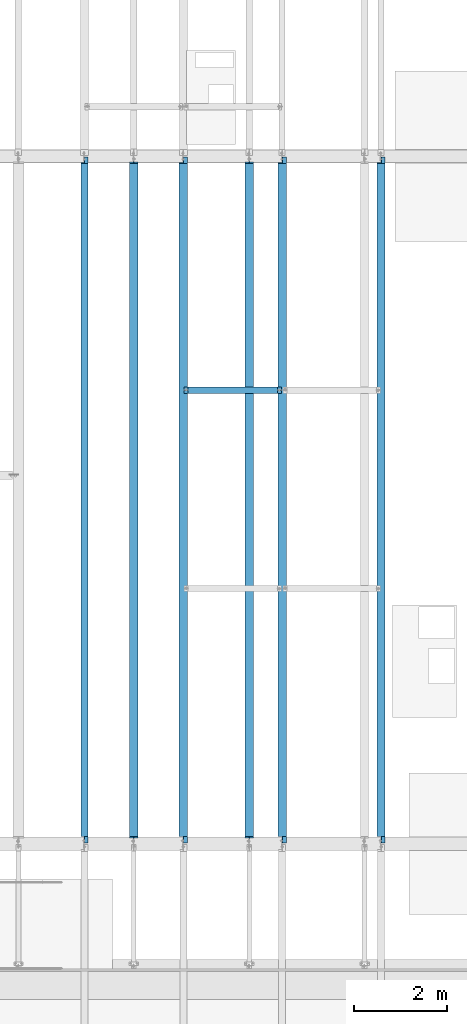
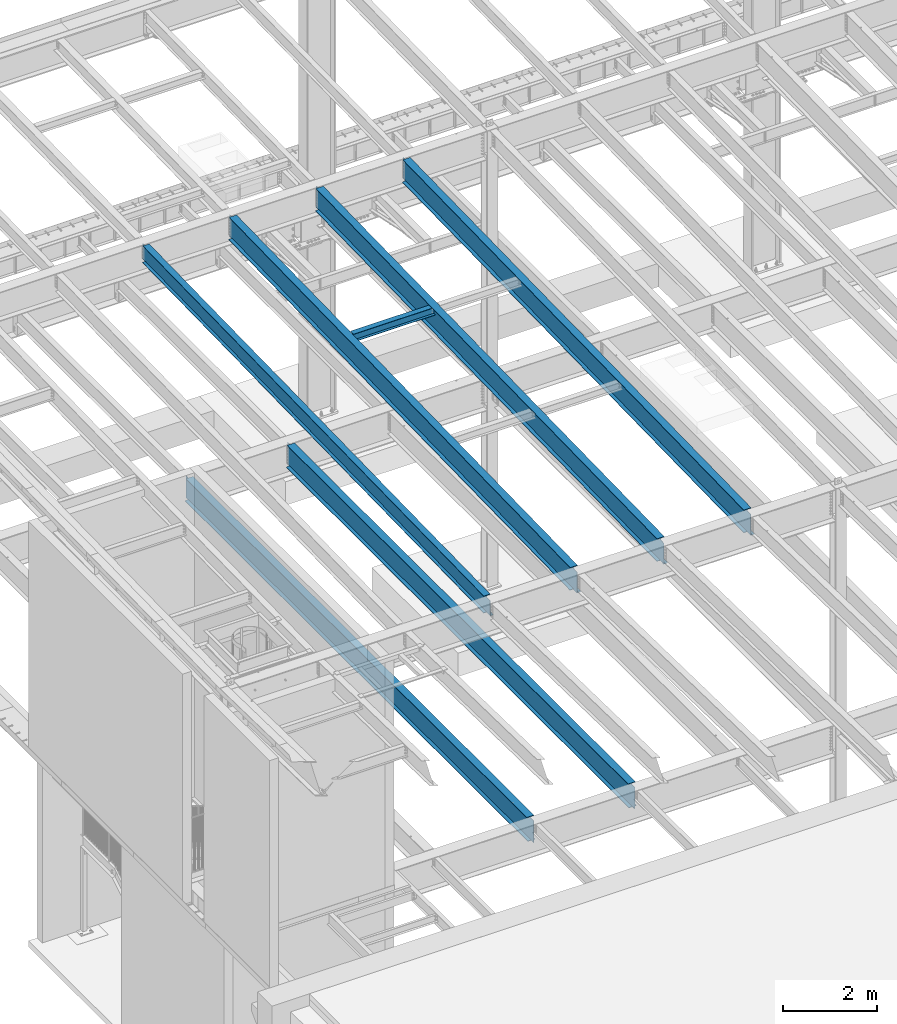
# One storey, part 1097 of 1763: 7 beams, 7 elements without a shape of their own.
"""IFC2X3 building model written with IfcOpenShell, lengths in millimetres."""

from ifc_helpers import new_model, si_unit, frame, origin_with_axes, place, context, subcontext, project, spatial, faceted_brep, material, type_object, element, aggregate, save


model = new_model("IFC2X3")

# Units and contexts
model_context = context("Model", 3, precision=1e-05, world=origin_with_axes())
body_context = subcontext(model_context, "Body", "Model", "MODEL_VIEW")
ifc_project = project(units=[si_unit("LENGTHUNIT", "METRE", prefix="MILLI"), si_unit("AREAUNIT", "SQUARE_METRE"), si_unit("VOLUMEUNIT", "CUBIC_METRE"), si_unit("MASSUNIT", "GRAM", prefix="KILO"), si_unit("TIMEUNIT", "SECOND"), si_unit("PLANEANGLEUNIT", "RADIAN"), si_unit("SOLIDANGLEUNIT", "STERADIAN"), si_unit("THERMODYNAMICTEMPERATUREUNIT", "DEGREE_CELSIUS"), si_unit("LUMINOUSINTENSITYUNIT", "LUMEN")], contexts=[model_context])

# Site, building, storey
site_placement = place(None, origin_with_axes())
site = spatial("IfcSite", under=ifc_project, at=site_placement, CompositionType="ELEMENT")
building_placement = place(site_placement, origin_with_axes())
building = spatial("IfcBuilding", under=site, at=building_placement, Name="Undefined", CompositionType="ELEMENT")
storey_placement = place(building_placement, origin_with_axes())
storey = spatial("IfcBuildingStorey", under=building, at=storey_placement, Name="Undefined", CompositionType="ELEMENT", Elevation=0.0)

# Assembly, beam
assembly_1_placement = place(storey_placement, origin_with_axes())
assembly_1 = element("IfcElementAssembly", 1, at=assembly_1_placement, inside=storey, Name="BEAM", AssemblyPlace="NOTDEFINED", PredefinedType="RIGID_FRAME")
ifc_material = material(Name="STEEL/A992")
beam_type_1 = type_object("IfcBeamType", Name="W8X18", PredefinedType="NOTDEFINED")
beam_1_placement = place(assembly_1_placement, frame((-78870.0658451269, 39776.4, 11388.9111170495), z_axis=(0.0, 0.0, 1.0), x_axis=(1.0, 0.0, 0.0)))
beam_1 = element("IfcBeam", 2, at=beam_1_placement, type_object=beam_type_1, material=ifc_material, Name="BEAM", ObjectType="W8X18", context=body_context, shape_type="Brep", body=[
    faceted_brep([(2030.05010096592, -3.17500000000018, 68.5472454972532), (2030.05010096592, 3.17500000000018, 68.5472454972532), (2029.18911617418, 3.17500000000291, 69.8358002989789), (2029.18911617418, -3.17500000000291, 69.8358002989789), (2034.17027743408, -3.17500000000018, 65.7942315967757), (2034.17027743408, 3.17500000000018, 65.7942315967757), (2039.03035695212, -3.17500000000018, 64.8275016741882), (2039.03035695212, 3.17500000000018, 64.8275016741882), (2108.88035714286, -3.17500000000018, 64.8275016741882), (2108.88035714286, 3.17500000000018, 64.8275016741882), (2028.46260401768, -3.17500000000291, 70.3212402021363), (2028.46260401768, 3.17500000000291, 70.3212402021363), (2025.7095901172, 3.17500000000291, 74.44141667029), (2025.7095901172, -3.17500000000291, 74.44141667029), (2024.74286019462, 3.17500000000291, 79.3014961883364), (2024.74286019462, -3.17500000000291, 79.3014961883364), (2024.74286019463, 66.6750000000002, 95.25), (2024.74286019463, 3.17500000000018, 95.25), (101.599996948244, 3.17500000000018, 95.25), (101.599996948244, 66.6750000000002, 95.25), (2024.74286019463, -66.6750000000002, 95.25), (2024.74286019463, -66.6750000000002, 103.1875), (101.599996948244, -66.6750000000002, 103.1875), (101.599996948244, -66.6750000000002, 95.25), (2024.74286019463, 66.6750000000002, 103.1875), (101.599996948244, 66.6750000000002, 103.1875), (2024.74286019463, -3.17500000000018, 95.25), (101.599996948244, -3.17500000000018, 95.25), (101.599996948236, 3.17499999999927, 79.301496189446), (101.599996948236, -3.17499999999927, 79.301496189446), (100.633267025652, 3.17499999999927, 74.4414166713996), (100.633267025652, -3.17499999999927, 74.4414166713996), (97.8802531251713, 3.17499999999927, 70.3212402032459), (97.8802531251713, -3.17499999999927, 70.3212402032459), (97.153740969894, 3.17499999999927, 69.8358003008998), (97.153740969894, -3.17499999999927, 69.8358003008998), (96.2927561769247, 3.17500000000018, 68.5472454911378), (96.2927561769247, -3.17500000000018, 68.5472454911378), (92.1725797087711, 3.17500000000018, 65.7942315906603), (92.1725797087711, -3.17500000000018, 65.7942315906603), (87.3125001907247, 3.17500000000018, 64.8275016680727), (87.3125001907247, -3.17500000000018, 64.8275016680727), (17.4624999999905, 3.17500000000018, 64.8275016680727), (17.4624999999905, -3.17500000000018, 64.8275016680727), (17.4624999999905, 3.17500000000018, -95.25), (17.4624999999905, 66.6750000000002, -95.25), (17.4624999999905, 66.6750000000002, -103.1875), (17.4624999999905, -66.6750000000002, -103.1875), (17.4624999999905, -66.6750000000002, -95.25), (17.4624999999905, -3.17500000000018, -95.25), (2108.88035714286, 3.17500000000018, -95.25), (2108.88035714286, 66.6750000000002, -95.25), (2108.88035714286, 66.6750000000002, -103.1875), (2108.88035714286, -66.6750000000002, -103.1875), (2108.88035714286, -66.6750000000002, -95.25), (2108.88035714286, -3.17500000000018, -95.25)], [[[0, 1, 2, 3]], [[4, 5, 1, 0]], [[6, 7, 5, 4]], [[8, 9, 7, 6]], [[10, 11, 12, 13]], [[13, 12, 14, 15]], [[16, 17, 18, 19]], [[20, 21, 22, 23]], [[21, 24, 25, 22]], [[24, 16, 19, 25]], [[21, 20, 26, 15, 14, 17, 16, 24]], [[26, 20, 23, 27]], [[22, 25, 19, 18, 28, 29, 27, 23]], [[29, 28, 30, 31]], [[31, 30, 32, 33]], [[33, 32, 34, 35]], [[35, 34, 36, 37]], [[37, 36, 38, 39]], [[39, 38, 40, 41]], [[41, 40, 42, 43]], [[44, 45, 46, 47, 48, 49, 43, 42]], [[45, 44, 50, 51]], [[46, 45, 51, 52]], [[47, 46, 52, 53]], [[48, 47, 53, 54]], [[49, 48, 54, 55]], [[4, 0, 3, 10, 13, 15, 26, 27, 29, 31, 33, 35, 37, 39, 41, 43, 49, 55, 8, 6]], [[11, 10, 3, 2]], [[50, 44, 42, 40, 38, 36, 34, 32, 30, 28, 18, 17, 14, 12, 11, 2, 1, 5, 7, 9]], [[55, 54, 53, 52, 51, 50, 9, 8]]]),
])
aggregate(assembly_1, [beam_1])

assembly_2_placement = place(storey_placement, origin_with_axes())
assembly_2 = element("IfcElementAssembly", 3, at=assembly_2_placement, inside=storey, Name="BEAM", AssemblyPlace="NOTDEFINED", PredefinedType="RIGID_FRAME")
beam_type_2 = type_object("IfcBeamType", Name="W18X35", PredefinedType="NOTDEFINED")
beam_2_placement = place(assembly_2_placement, frame((-80996.4087022698, 30027.4629676506, 11064.9232324289), z_axis=(0.0, -0.0206852279954837, 0.999786037781472), x_axis=(0.0, 0.999786037781472, 0.0206852279954825)))
beam_2 = element("IfcBeam", 4, at=beam_2_placement, type_object=beam_type_2, material=ifc_material, Name="BEAM", ObjectType="W18X35", context=body_context, shape_type="Brep", body=[
    faceted_brep([(161.234036217043, 4.26867060289806, -214.312499999869), (161.234036217025, 4.26882632687921, -225.424999999863), (10.5200655540102, 4.26881607816904, -225.424999999832), (10.7499793429743, 4.26866036980209, -214.312499999842), (161.234031325755, 76.1999999999971, -214.312499999867), (161.234031325748, 76.1999999999971, -225.424999999861), (161.234031013333, -3.96875, 180.714997672841), (161.234031013333, 3.96875, 180.714997672841), (160.267301090749, 3.96875, 175.854918154808), (160.267301090749, -3.96875, 175.854918154808), (157.514287190275, 3.96875, 171.734741686663), (157.514287190275, -3.96875, 171.734741686663), (153.394110722133, 3.96875, 168.981727786193), (153.394110722133, -3.96875, 168.981727786193), (148.534031204097, 3.96875, 168.014997863607), (148.534031204097, -3.96875, 168.014997863607), (18.6602033211384, 3.96875, 168.014997863631), (18.6602033211384, -3.96875, 168.014997863631), (10.7499793429743, -3.96875, -214.312499999842), (14757.8115434472, -3.96875, -214.312500002648), (14765.8531467846, -3.96875, 174.36500163611), (14641.5955948759, -3.96875, 174.365001636133), (14636.7355153579, -3.96875, 175.331731558719), (14632.6153388897, -3.96875, 178.084745459191), (14629.8623249892, -3.96875, 182.204921927336), (14628.8955950666, -3.96875, 187.065001445368), (14628.8955950666, -3.96875, 214.312499997053), (161.234030986467, -3.96875, 214.312499999809), (10.7499793429743, -76.1999999999971, -214.312499999842), (14757.8115434472, -76.1999999999971, -214.312500002648), (10.5200655540102, -76.1999999999971, -225.424999999832), (14757.5816296582, -76.1999999999971, -225.425000002639), (14641.5955921487, 4.26882640406257, -214.312500002627), (14641.5955921487, 4.26867068048159, -225.425000002617), (14641.5955830855, 76.1999999999971, -225.425000002617), (14641.5955830855, 76.1999999999971, -214.312500002628), (14757.8115434472, 4.26884104704368, -214.312500002648), (14757.5816296582, 4.26868529446074, -225.425000002639), (14757.8115434472, 3.96875, -214.312500002648), (14765.8531467846, 3.96875, 174.36500163611), (14641.5955948759, 3.96875, 174.365001636133), (14636.7355153579, 3.96875, 175.331731558719), (14632.6153388897, 3.96875, 178.084745459191), (14629.8623249892, 3.96875, 182.204921927336), (14628.8955950666, 3.96875, 187.065001445368), (14628.8955950666, -76.1999999999971, 225.424999997045), (14628.8955950666, -76.1999999999971, 214.312499997053), (14628.8955950666, 3.96875, 214.312499997053), (14628.8955950666, 76.1999999999971, 214.312499997053), (14628.8955950666, 76.1999999999971, 225.424999997045), (161.234030986467, 3.96875, 214.312499999809), (161.234030986467, 76.1999999999971, 214.312499999809), (161.23403098647, 76.1999999999971, 225.424999999799), (161.23403098647, -76.1999999999971, 225.424999999799), (161.234030986467, -76.1999999999971, 214.312499999809), (10.7499793429743, 3.96875, -214.312499999842)], [[[0, 1, 2, 3]], [[4, 5, 1, 0]], [[6, 7, 8, 9]], [[9, 8, 10, 11]], [[11, 10, 12, 13]], [[13, 12, 14, 15]], [[15, 14, 16, 17]], [[9, 11, 13, 15, 17, 18, 19, 20, 21, 22, 23, 24, 25, 26, 27, 6]], [[18, 28, 29, 19]], [[28, 30, 31, 29]], [[32, 33, 34, 35]], [[36, 37, 33, 32]], [[38, 39, 20, 19, 29, 31, 37, 36]], [[20, 39, 40, 21]], [[21, 40, 41, 22]], [[22, 41, 42, 23]], [[23, 42, 43, 24]], [[24, 43, 44, 25]], [[45, 46, 26, 25, 44, 47, 48, 49]], [[48, 47, 50, 51]], [[49, 48, 51, 52]], [[45, 49, 52, 53]], [[46, 45, 53, 54]], [[26, 46, 54, 27]], [[53, 52, 51, 50, 7, 6, 27, 54]], [[47, 44, 43, 42, 41, 40, 39, 38, 55, 16, 14, 12, 10, 8, 7, 50]], [[30, 28, 18, 17, 16, 55, 3, 2]], [[34, 33, 37, 31, 30, 2, 1, 5]], [[35, 34, 5, 4]], [[55, 38, 36, 32, 35, 4, 0, 3]]]),
])
aggregate(assembly_2, [beam_2])

assembly_3_placement = place(storey_placement, origin_with_axes())
assembly_3 = element("IfcElementAssembly", 5, at=assembly_3_placement, inside=storey, Name="BEAM", AssemblyPlace="NOTDEFINED", PredefinedType="RIGID_FRAME")
beam_type_3 = type_object("IfcBeamType", Name="W24X55", PredefinedType="NOTDEFINED")
beam_3_placement = place(assembly_3_placement, frame((-74617.3801308412, 30029.0063442244, 10990.3266966851), z_axis=(0.0, -0.0206852279954837, 0.999786037781472), x_axis=(0.0, 0.999786037781472, 0.0206852279954825)))
beam_3 = element("IfcBeam", 6, at=beam_3_placement, type_object=beam_type_3, material=ifc_material, Name="BEAM", ObjectType="W24X55", context=body_context, shape_type="Brep", body=[
    faceted_brep([(159.690329536948, 5.06237880352273, -287.337499999812), (159.690329536945, 5.06261812614684, -300.037499999804), (7.43265181667448, 5.06260883843788, -300.037499999775), (7.69541043263234, 5.06236953187909, -287.337499999783), (159.690324423107, 88.9000000000015, -287.337499999812), (159.690324423103, 88.9000000000015, -300.037499999802), (159.690324144543, -4.76249999999709, 255.327497672615), (159.690324144543, 4.76249999999709, 255.327497672615), (158.723594221956, 4.76249999999709, 250.467418154582), (158.723594221956, -4.76249999999709, 250.467418154582), (155.970580321482, 4.76249999999709, 246.347241686437), (155.970580321482, -4.76249999999709, 246.347241686437), (151.850403853339, 4.76249999999709, 243.594227785965), (151.850403853339, -4.76249999999709, 243.594227785965), (146.990324335304, 4.76249999999709, 242.627497863381), (146.990324335304, -4.76249999999709, 242.627497863381), (18.6602033210984, 4.76249999999709, 242.627497863405), (18.6602033210984, -4.76249999999709, 242.627497863405), (7.69541043263234, -4.76249999999709, -287.337499999783), (14754.7569745369, -4.76249999999709, -287.337500002592), (14765.8531467848, -4.76249999999709, 248.977501635871), (14640.0518880073, -4.76249999999709, 248.977501635894), (14635.1918084892, -4.76249999999709, 249.944231558482), (14631.0716320211, -4.76249999999709, 252.697245458956), (14628.3186181206, -4.76249999999709, 256.817421927099), (14627.351888198, -4.76249999999709, 261.677501445134), (14627.351888198, -4.76249999999709, 287.337499997), (159.690324117902, -4.76249999999709, 287.337499999756), (7.69541043263234, -88.9000000000015, -287.337499999783), (14754.7569745369, -88.9000000000015, -287.337500002592), (7.43265181667448, -88.9000000000015, -300.037499999775), (14754.4942159209, -88.9000000000015, -300.037500002583), (14640.051883239, 5.06261810508295, -287.33750000257), (14640.051883239, 5.06237878320098, -300.03750000256), (14640.0518719211, 88.9000000000015, -300.037500002562), (14640.0518719211, 88.9000000000015, -287.337500002572), (14754.7569745369, 5.0626335900306, -287.337500002592), (14754.4942159209, 5.06239423266379, -300.037500002583), (14754.7569745369, 4.76249999999709, -287.337500002592), (14765.8531467848, 4.76249999999709, 248.977501635871), (14640.0518880073, 4.76249999999709, 248.977501635894), (14635.1918084892, 4.76249999999709, 249.944231558482), (14631.0716320211, 4.76249999999709, 252.697245458956), (14628.3186181206, 4.76249999999709, 256.817421927099), (14627.351888198, 4.76249999999709, 261.677501445134), (14627.351888198, -88.9000000000015, 300.03749999699), (14627.351888198, -88.9000000000015, 287.337499997), (14627.351888198, 4.76249999999709, 287.337499997), (14627.351888198, 88.9000000000015, 287.337499997), (14627.351888198, 88.9000000000015, 300.03749999699), (159.690324117902, 4.76249999999709, 287.337499999756), (159.690324117902, 88.9000000000015, 287.337499999756), (159.690324117906, 88.9000000000015, 300.037499999746), (159.690324117906, -88.9000000000015, 300.037499999746), (159.690324117902, -88.9000000000015, 287.337499999756), (7.69541043263234, 4.76249999999709, -287.337499999783)], [[[0, 1, 2, 3]], [[4, 5, 1, 0]], [[6, 7, 8, 9]], [[9, 8, 10, 11]], [[11, 10, 12, 13]], [[13, 12, 14, 15]], [[15, 14, 16, 17]], [[9, 11, 13, 15, 17, 18, 19, 20, 21, 22, 23, 24, 25, 26, 27, 6]], [[18, 28, 29, 19]], [[28, 30, 31, 29]], [[32, 33, 34, 35]], [[36, 37, 33, 32]], [[38, 39, 20, 19, 29, 31, 37, 36]], [[20, 39, 40, 21]], [[21, 40, 41, 22]], [[22, 41, 42, 23]], [[23, 42, 43, 24]], [[24, 43, 44, 25]], [[45, 46, 26, 25, 44, 47, 48, 49]], [[48, 47, 50, 51]], [[49, 48, 51, 52]], [[45, 49, 52, 53]], [[46, 45, 53, 54]], [[26, 46, 54, 27]], [[53, 52, 51, 50, 7, 6, 27, 54]], [[47, 44, 43, 42, 41, 40, 39, 38, 55, 16, 14, 12, 10, 8, 7, 50]], [[30, 28, 18, 17, 16, 55, 3, 2]], [[34, 33, 37, 31, 30, 2, 1, 5]], [[35, 34, 5, 4]], [[55, 38, 36, 32, 35, 4, 0, 3]]]),
])
aggregate(assembly_3, [beam_3])

assembly_4_placement = place(storey_placement, origin_with_axes())
assembly_4 = element("IfcElementAssembly", 7, at=assembly_4_placement, inside=storey, Name="BEAM", AssemblyPlace="NOTDEFINED", PredefinedType="RIGID_FRAME")
beam_4_placement = place(assembly_4_placement, frame((-76743.7229879841, 30029.0063442244, 10990.3266966851), z_axis=(0.0, -0.0206852279954837, 0.999786037781472), x_axis=(0.0, 0.999786037781472, 0.0206852279954825)))
beam_4 = element("IfcBeam", 8, at=beam_4_placement, type_object=beam_type_3, material=ifc_material, Name="BEAM", ObjectType="W24X55", context=body_context, shape_type="Brep", body=[
    faceted_brep([(159.690329536948, 5.06237880352273, -287.337499999812), (159.690329536945, 5.06261812614684, -300.037499999804), (7.43265181667448, 5.06260883843788, -300.037499999775), (7.69541043263234, 5.06236953187909, -287.337499999783), (159.690324423107, 88.9000000000015, -287.337499999812), (159.690324423103, 88.9000000000015, -300.037499999802), (159.690324144543, -4.76249999999709, 255.327497672615), (159.690324144543, 4.76249999999709, 255.327497672615), (158.723594221956, 4.76249999999709, 250.467418154582), (158.723594221956, -4.76249999999709, 250.467418154582), (155.970580321482, 4.76249999999709, 246.347241686437), (155.970580321482, -4.76249999999709, 246.347241686437), (151.850403853339, 4.76249999999709, 243.594227785965), (151.850403853339, -4.76249999999709, 243.594227785965), (146.990324335304, 4.76249999999709, 242.627497863381), (146.990324335304, -4.76249999999709, 242.627497863381), (18.6602033210984, 4.76249999999709, 242.627497863405), (18.6602033210984, -4.76249999999709, 242.627497863405), (7.69541043263234, -4.76249999999709, -287.337499999783), (14754.7569745369, -4.76249999999709, -287.337500002592), (14765.8531467848, -4.76249999999709, 248.977501635871), (14640.0518880073, -4.76249999999709, 248.977501635894), (14635.1918084892, -4.76249999999709, 249.944231558482), (14631.0716320211, -4.76249999999709, 252.697245458956), (14628.3186181206, -4.76249999999709, 256.817421927099), (14627.351888198, -4.76249999999709, 261.677501445134), (14627.351888198, -4.76249999999709, 287.337499997), (159.690324117902, -4.76249999999709, 287.337499999756), (7.69541043263234, -88.9000000000015, -287.337499999783), (14754.7569745369, -88.9000000000015, -287.337500002592), (7.43265181667448, -88.9000000000015, -300.037499999775), (14754.4942159209, -88.9000000000015, -300.037500002583), (14640.051883239, 5.06261810508295, -287.33750000257), (14640.051883239, 5.06237878320098, -300.03750000256), (14640.0518719211, 88.9000000000015, -300.037500002562), (14640.0518719211, 88.9000000000015, -287.337500002572), (14754.7569745369, 5.0626335900306, -287.337500002592), (14754.4942159209, 5.06239423266379, -300.037500002583), (14754.7569745369, 4.76249999999709, -287.337500002592), (14765.8531467848, 4.76249999999709, 248.977501635871), (14640.0518880073, 4.76249999999709, 248.977501635894), (14635.1918084892, 4.76249999999709, 249.944231558482), (14631.0716320211, 4.76249999999709, 252.697245458956), (14628.3186181206, 4.76249999999709, 256.817421927099), (14627.351888198, 4.76249999999709, 261.677501445134), (14627.351888198, -88.9000000000015, 300.03749999699), (14627.351888198, -88.9000000000015, 287.337499997), (14627.351888198, 4.76249999999709, 287.337499997), (14627.351888198, 88.9000000000015, 287.337499997), (14627.351888198, 88.9000000000015, 300.03749999699), (159.690324117902, 4.76249999999709, 287.337499999756), (159.690324117902, 88.9000000000015, 287.337499999756), (159.690324117906, 88.9000000000015, 300.037499999746), (159.690324117906, -88.9000000000015, 300.037499999746), (159.690324117902, -88.9000000000015, 287.337499999756), (7.69541043263234, 4.76249999999709, -287.337499999783)], [[[0, 1, 2, 3]], [[4, 5, 1, 0]], [[6, 7, 8, 9]], [[9, 8, 10, 11]], [[11, 10, 12, 13]], [[13, 12, 14, 15]], [[15, 14, 16, 17]], [[9, 11, 13, 15, 17, 18, 19, 20, 21, 22, 23, 24, 25, 26, 27, 6]], [[18, 28, 29, 19]], [[28, 30, 31, 29]], [[32, 33, 34, 35]], [[36, 37, 33, 32]], [[38, 39, 20, 19, 29, 31, 37, 36]], [[20, 39, 40, 21]], [[21, 40, 41, 22]], [[22, 41, 42, 23]], [[23, 42, 43, 24]], [[24, 43, 44, 25]], [[45, 46, 26, 25, 44, 47, 48, 49]], [[48, 47, 50, 51]], [[49, 48, 51, 52]], [[45, 49, 52, 53]], [[46, 45, 53, 54]], [[26, 46, 54, 27]], [[53, 52, 51, 50, 7, 6, 27, 54]], [[47, 44, 43, 42, 41, 40, 39, 38, 55, 16, 14, 12, 10, 8, 7, 50]], [[30, 28, 18, 17, 16, 55, 3, 2]], [[34, 33, 37, 31, 30, 2, 1, 5]], [[35, 34, 5, 4]], [[55, 38, 36, 32, 35, 4, 0, 3]]]),
])
aggregate(assembly_4, [beam_4])

assembly_5_placement = place(storey_placement, origin_with_axes())
assembly_5 = element("IfcElementAssembly", 9, at=assembly_5_placement, inside=storey, Name="BEAM", AssemblyPlace="NOTDEFINED", PredefinedType="RIGID_FRAME")
beam_5_placement = place(assembly_5_placement, frame((-78870.0658451269, 30029.0063442244, 10990.3266966851), z_axis=(0.0, -0.0206852279954837, 0.999786037781472), x_axis=(0.0, 0.999786037781472, 0.0206852279954825)))
beam_5 = element("IfcBeam", 10, at=beam_5_placement, type_object=beam_type_3, material=ifc_material, Name="BEAM", ObjectType="W24X55", context=body_context, shape_type="Brep", body=[
    faceted_brep([(159.690329536948, 5.06237880352273, -287.337499999812), (159.690329536945, 5.06261812614684, -300.037499999804), (7.43265181667448, 5.06260883843788, -300.037499999775), (7.69541043263234, 5.06236953187909, -287.337499999783), (159.690324423107, 88.9000000000015, -287.337499999812), (159.690324423103, 88.9000000000015, -300.037499999802), (159.690324144543, -4.76249999999709, 255.327497672615), (159.690324144543, 4.76249999999709, 255.327497672615), (158.723594221956, 4.76249999999709, 250.467418154582), (158.723594221956, -4.76249999999709, 250.467418154582), (155.970580321482, 4.76249999999709, 246.347241686437), (155.970580321482, -4.76249999999709, 246.347241686437), (151.850403853339, 4.76249999999709, 243.594227785965), (151.850403853339, -4.76249999999709, 243.594227785965), (146.990324335304, 4.76249999999709, 242.627497863381), (146.990324335304, -4.76249999999709, 242.627497863381), (18.6602033210984, 4.76249999999709, 242.627497863405), (18.6602033210984, -4.76249999999709, 242.627497863405), (7.69541043263234, -4.76249999999709, -287.337499999783), (14754.7569745369, -4.76249999999709, -287.337500002592), (14765.8531467848, -4.76249999999709, 248.977501635871), (14640.0518880073, -4.76249999999709, 248.977501635894), (14635.1918084892, -4.76249999999709, 249.944231558482), (14631.0716320211, -4.76249999999709, 252.697245458956), (14628.3186181206, -4.76249999999709, 256.817421927099), (14627.351888198, -4.76249999999709, 261.677501445134), (14627.351888198, -4.76249999999709, 287.337499997), (159.690324117902, -4.76249999999709, 287.337499999756), (7.69541043263234, -88.9000000000015, -287.337499999783), (14754.7569745369, -88.9000000000015, -287.337500002592), (7.43265181667448, -88.9000000000015, -300.037499999775), (14754.4942159209, -88.9000000000015, -300.037500002583), (14640.051883239, 5.06261810508295, -287.33750000257), (14640.051883239, 5.06237878320098, -300.03750000256), (14640.0518719211, 88.9000000000015, -300.037500002562), (14640.0518719211, 88.9000000000015, -287.337500002572), (14754.7569745369, 5.0626335900306, -287.337500002592), (14754.4942159209, 5.06239423266379, -300.037500002583), (14754.7569745369, 4.76249999999709, -287.337500002592), (14765.8531467848, 4.76249999999709, 248.977501635871), (14640.0518880073, 4.76249999999709, 248.977501635894), (14635.1918084892, 4.76249999999709, 249.944231558482), (14631.0716320211, 4.76249999999709, 252.697245458956), (14628.3186181206, 4.76249999999709, 256.817421927099), (14627.351888198, 4.76249999999709, 261.677501445134), (14627.351888198, -88.9000000000015, 300.03749999699), (14627.351888198, -88.9000000000015, 287.337499997), (14627.351888198, 4.76249999999709, 287.337499997), (14627.351888198, 88.9000000000015, 287.337499997), (14627.351888198, 88.9000000000015, 300.03749999699), (159.690324117902, 4.76249999999709, 287.337499999756), (159.690324117902, 88.9000000000015, 287.337499999756), (159.690324117906, 88.9000000000015, 300.037499999746), (159.690324117906, -88.9000000000015, 300.037499999746), (159.690324117902, -88.9000000000015, 287.337499999756), (7.69541043263234, 4.76249999999709, -287.337499999783)], [[[0, 1, 2, 3]], [[4, 5, 1, 0]], [[6, 7, 8, 9]], [[9, 8, 10, 11]], [[11, 10, 12, 13]], [[13, 12, 14, 15]], [[15, 14, 16, 17]], [[9, 11, 13, 15, 17, 18, 19, 20, 21, 22, 23, 24, 25, 26, 27, 6]], [[18, 28, 29, 19]], [[28, 30, 31, 29]], [[32, 33, 34, 35]], [[36, 37, 33, 32]], [[38, 39, 20, 19, 29, 31, 37, 36]], [[20, 39, 40, 21]], [[21, 40, 41, 22]], [[22, 41, 42, 23]], [[23, 42, 43, 24]], [[24, 43, 44, 25]], [[45, 46, 26, 25, 44, 47, 48, 49]], [[48, 47, 50, 51]], [[49, 48, 51, 52]], [[45, 49, 52, 53]], [[46, 45, 53, 54]], [[26, 46, 54, 27]], [[53, 52, 51, 50, 7, 6, 27, 54]], [[47, 44, 43, 42, 41, 40, 39, 38, 55, 16, 14, 12, 10, 8, 7, 50]], [[30, 28, 18, 17, 16, 55, 3, 2]], [[34, 33, 37, 31, 30, 2, 1, 5]], [[35, 34, 5, 4]], [[55, 38, 36, 32, 35, 4, 0, 3]]]),
])
aggregate(assembly_5, [beam_5])

assembly_6_placement = place(storey_placement, origin_with_axes())
assembly_6 = element("IfcElementAssembly", 11, at=assembly_6_placement, inside=storey, Name="BEAM", AssemblyPlace="NOTDEFINED", PredefinedType="RIGID_FRAME")
beam_6_placement = place(assembly_6_placement, frame((-79933.2372736984, 30022.8, 4894.2625), z_axis=(0.0, 0.0, 1.0), x_axis=(0.0, 1.0, 0.0)))
beam_6 = element("IfcBeam", 12, at=beam_6_placement, type_object=beam_type_3, material=ifc_material, Name="BEAM", ObjectType="W24X55", context=body_context, shape_type="Brep", body=[
    faceted_brep([(19.8437500000036, -5.06263076800678, -287.3375), (19.8437500000036, -5.06239138569799, -300.0375), (121.443760724065, -5.06237878766842, -300.0375), (121.443760724113, -5.06261816997721, -287.3375), (121.443815955325, -88.9000000000015, -287.3375), (121.443815955325, -88.9000000000015, -300.0375), (159.543750000004, -4.76249999999709, 280.727501487732), (159.543750000004, 4.76249999999709, 280.727501487732), (158.577020077417, 4.76249999999709, 275.867421969687), (158.577020077417, -4.76249999999709, 275.867421969687), (155.824006176939, 4.76249999999709, 271.747245501533), (155.824006176939, -4.76249999999709, 271.747245501533), (151.703829708786, 4.76249999999709, 268.994231601055), (151.703829708786, -4.76249999999709, 268.994231601055), (146.843750190739, 4.76249999999709, 268.027501678467), (146.843750190739, -4.76249999999709, 268.027501678467), (19.8437500000036, 4.76249999999709, 268.027501678467), (19.8437500000036, -4.76249999999709, 268.027501678467), (19.84375, -4.76249999999709, -287.3375), (14762.95625, -4.76249999999709, -287.3375), (14762.95625, -4.76249999999709, 268.027501678467), (14635.9562498093, -4.76249999999709, 268.027501678467), (14631.0961702912, -4.76249999999709, 268.994231601055), (14626.9759938231, -4.76249999999709, 271.747245501533), (14624.2229799226, -4.76249999999709, 275.867421969687), (14623.25625, -4.76249999999709, 280.727501487732), (14623.25625, -4.76249999999709, 287.3375), (159.543750000004, -4.76249999999709, 287.3375), (14762.95625, 4.76249999999709, 268.027501678467), (14635.9562498093, 4.76249999999709, 268.027501678467), (14631.0961702912, 4.76249999999709, 268.994231601055), (14626.9759938231, 4.76249999999709, 271.747245501533), (14624.2229799226, 4.76249999999709, 275.867421969687), (14623.25625, 4.76249999999709, 280.727501487732), (14623.25625, -88.8999999999942, 300.0375), (14623.25625, -88.8999999999942, 287.3375), (14623.25625, 4.76249999999709, 287.3375), (14623.25625, 88.8999999999942, 287.3375), (14623.25625, 88.8999999999942, 300.0375), (159.543750000004, 4.76249999999709, 287.3375), (159.543750000004, 88.8999999999942, 287.3375), (159.543750000004, 88.8999999999942, 300.0375), (159.543750000004, -88.8999999999942, 300.0375), (159.543750000004, -88.8999999999942, 287.3375), (14762.95625, 4.76249999999709, -287.3375), (19.84375, 4.76249999999709, -287.3375), (14762.95625, 5.0626307680941, -287.3375), (14661.3562392746, 5.06261817002087, -287.3375), (14661.356228879, 88.8999999999942, -287.3375), (121.443751839222, 88.9000000000015, -287.3375), (121.443761016704, 5.06237876559317, -287.3375), (19.8437500000036, 5.06236616715614, -287.3375), (121.443761016661, 5.06261814791651, -300.0375), (19.8437500000036, 5.06260554946493, -300.0375), (121.443751839222, 88.9000000000015, -300.0375), (14661.356228879, 88.8999999999942, -300.0375), (14661.3562392746, 5.06237878771208, -300.0375), (14762.95625, 5.0623913857853, -300.0375), (14762.95625, -5.06236616667593, -287.3375), (14762.95625, -5.06260554897017, -300.0375), (14661.3562389844, -5.0623787647346, -287.3375), (14661.3562389844, -5.06261814705795, -300.0375), (14661.3562493798, -88.8999999999942, -287.3375), (14661.3562493798, -88.8999999999942, -300.0375)], [[[0, 1, 2, 3]], [[4, 3, 2, 5]], [[6, 7, 8, 9]], [[9, 8, 10, 11]], [[11, 10, 12, 13]], [[13, 12, 14, 15]], [[15, 14, 16, 17]], [[9, 11, 13, 15, 17, 18, 19, 20, 21, 22, 23, 24, 25, 26, 27, 6]], [[20, 28, 29, 21]], [[21, 29, 30, 22]], [[22, 30, 31, 23]], [[23, 31, 32, 24]], [[24, 32, 33, 25]], [[34, 35, 26, 25, 33, 36, 37, 38]], [[37, 36, 39, 40]], [[38, 37, 40, 41]], [[34, 38, 41, 42]], [[35, 34, 42, 43]], [[26, 35, 43, 27]], [[42, 41, 40, 39, 7, 6, 27, 43]], [[36, 33, 32, 31, 30, 29, 28, 44, 45, 16, 14, 12, 10, 8, 7, 39]], [[45, 44, 46, 47, 48, 49, 50, 51]], [[50, 52, 53, 51]], [[49, 54, 52, 50]], [[48, 55, 54, 49]], [[47, 56, 55, 48]], [[46, 57, 56, 47]], [[44, 28, 20, 19, 58, 59, 57, 46]], [[58, 60, 61, 59]], [[62, 63, 61, 60]], [[63, 62, 4, 5]], [[1, 53, 52, 54, 55, 56, 57, 59, 61, 63, 5, 2]], [[18, 17, 16, 45, 51, 53, 1, 0]], [[62, 60, 58, 19, 18, 0, 3, 4]]]),
])
aggregate(assembly_6, [beam_6])

assembly_7_placement = place(storey_placement, origin_with_axes())
assembly_7 = element("IfcElementAssembly", 13, at=assembly_7_placement, inside=storey, Name="BEAM", AssemblyPlace="NOTDEFINED", PredefinedType="RIGID_FRAME")
beam_7_placement = place(assembly_7_placement, frame((-77452.5700856983, 30022.8, 4894.2625), z_axis=(0.0, 0.0, 1.0), x_axis=(0.0, 1.0, 0.0)))
beam_7 = element("IfcBeam", 14, at=beam_7_placement, type_object=beam_type_3, material=ifc_material, Name="BEAM", ObjectType="W24X55", context=body_context, shape_type="Brep", body=[
    faceted_brep([(19.8437500000036, -5.06263076800678, -287.3375), (19.8437500000036, -5.06239138569799, -300.0375), (121.443760724065, -5.06237878766842, -300.0375), (121.443760724113, -5.06261816997721, -287.3375), (121.443815955325, -88.9000000000015, -287.3375), (121.443815955325, -88.9000000000015, -300.0375), (159.543750000004, -4.76249999999709, 280.727501487732), (159.543750000004, 4.76249999999709, 280.727501487732), (158.577020077417, 4.76249999999709, 275.867421969687), (158.577020077417, -4.76249999999709, 275.867421969687), (155.824006176939, 4.76249999999709, 271.747245501533), (155.824006176939, -4.76249999999709, 271.747245501533), (151.703829708786, 4.76249999999709, 268.994231601055), (151.703829708786, -4.76249999999709, 268.994231601055), (146.843750190739, 4.76249999999709, 268.027501678467), (146.843750190739, -4.76249999999709, 268.027501678467), (19.8437500000036, 4.76249999999709, 268.027501678467), (19.8437500000036, -4.76249999999709, 268.027501678467), (19.84375, -4.76249999999709, -287.3375), (14762.95625, -4.76249999999709, -287.3375), (14762.95625, -4.76249999999709, 268.027501678467), (14635.9562498093, -4.76249999999709, 268.027501678467), (14631.0961702912, -4.76249999999709, 268.994231601055), (14626.9759938231, -4.76249999999709, 271.747245501533), (14624.2229799226, -4.76249999999709, 275.867421969687), (14623.25625, -4.76249999999709, 280.727501487732), (14623.25625, -4.76249999999709, 287.3375), (159.543750000004, -4.76249999999709, 287.3375), (14762.95625, 4.76249999999709, 268.027501678467), (14635.9562498093, 4.76249999999709, 268.027501678467), (14631.0961702912, 4.76249999999709, 268.994231601055), (14626.9759938231, 4.76249999999709, 271.747245501533), (14624.2229799226, 4.76249999999709, 275.867421969687), (14623.25625, 4.76249999999709, 280.727501487732), (14623.25625, -88.8999999999942, 300.0375), (14623.25625, -88.8999999999942, 287.3375), (14623.25625, 4.76249999999709, 287.3375), (14623.25625, 88.8999999999942, 287.3375), (14623.25625, 88.8999999999942, 300.0375), (159.543750000004, 4.76249999999709, 287.3375), (159.543750000004, 88.8999999999942, 287.3375), (159.543750000004, 88.8999999999942, 300.0375), (159.543750000004, -88.8999999999942, 300.0375), (159.543750000004, -88.8999999999942, 287.3375), (14762.95625, 4.76249999999709, -287.3375), (19.84375, 4.76249999999709, -287.3375), (14762.95625, 5.0626307680941, -287.3375), (14661.3562392746, 5.06261817002087, -287.3375), (14661.356228879, 88.8999999999942, -287.3375), (121.443751839222, 88.9000000000015, -287.3375), (121.443761016704, 5.06237876559317, -287.3375), (19.8437500000036, 5.06236616715614, -287.3375), (121.443761016661, 5.06261814791651, -300.0375), (19.8437500000036, 5.06260554946493, -300.0375), (121.443751839222, 88.9000000000015, -300.0375), (14661.356228879, 88.8999999999942, -300.0375), (14661.3562392746, 5.06237878771208, -300.0375), (14762.95625, 5.0623913857853, -300.0375), (14762.95625, -5.06236616667593, -287.3375), (14762.95625, -5.06260554897017, -300.0375), (14661.3562389844, -5.0623787647346, -287.3375), (14661.3562389844, -5.06261814705795, -300.0375), (14661.3562493798, -88.8999999999942, -287.3375), (14661.3562493798, -88.8999999999942, -300.0375)], [[[0, 1, 2, 3]], [[4, 3, 2, 5]], [[6, 7, 8, 9]], [[9, 8, 10, 11]], [[11, 10, 12, 13]], [[13, 12, 14, 15]], [[15, 14, 16, 17]], [[9, 11, 13, 15, 17, 18, 19, 20, 21, 22, 23, 24, 25, 26, 27, 6]], [[20, 28, 29, 21]], [[21, 29, 30, 22]], [[22, 30, 31, 23]], [[23, 31, 32, 24]], [[24, 32, 33, 25]], [[34, 35, 26, 25, 33, 36, 37, 38]], [[37, 36, 39, 40]], [[38, 37, 40, 41]], [[34, 38, 41, 42]], [[35, 34, 42, 43]], [[26, 35, 43, 27]], [[42, 41, 40, 39, 7, 6, 27, 43]], [[36, 33, 32, 31, 30, 29, 28, 44, 45, 16, 14, 12, 10, 8, 7, 39]], [[45, 44, 46, 47, 48, 49, 50, 51]], [[50, 52, 53, 51]], [[49, 54, 52, 50]], [[48, 55, 54, 49]], [[47, 56, 55, 48]], [[46, 57, 56, 47]], [[44, 28, 20, 19, 58, 59, 57, 46]], [[58, 60, 61, 59]], [[62, 63, 61, 60]], [[63, 62, 4, 5]], [[1, 53, 52, 54, 55, 56, 57, 59, 61, 63, 5, 2]], [[18, 17, 16, 45, 51, 53, 1, 0]], [[62, 60, 58, 19, 18, 0, 3, 4]]]),
])
aggregate(assembly_7, [beam_7])

save(model, "model.ifc")
